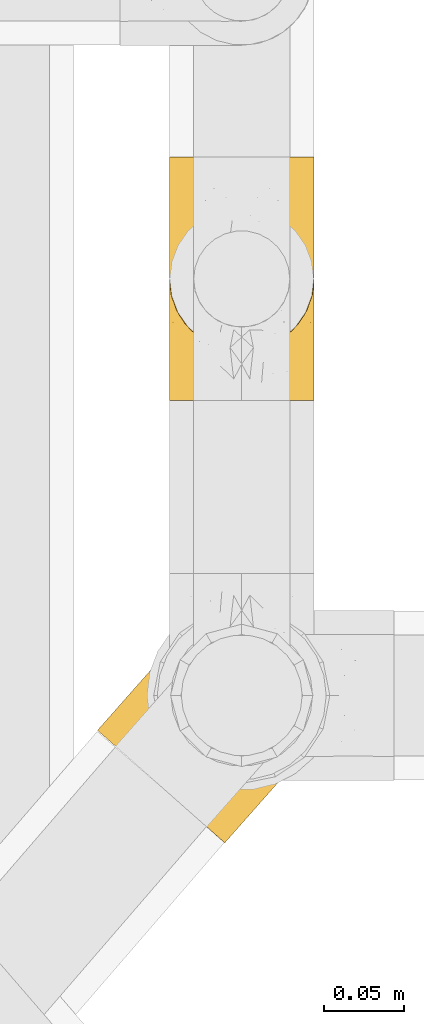
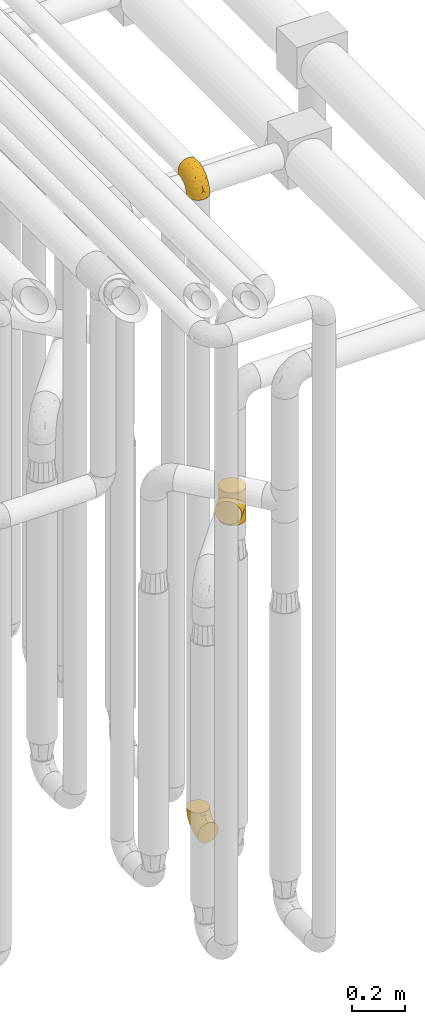
# One storey, part 207 of 827: 3 coverings.
"""IFC2X3 building model written with IfcOpenShell, lengths in millimetres."""

from ifc_helpers import new_model, entity, si_unit, converted_unit, derived_unit, direction, frame, origin, place, context, subcontext, project, spatial, faceted_brep, element, save


model = new_model("IFC2X3")

# Units and contexts
model_context = context("Model", 3, precision=0.01, world=origin(), true_north=direction((6.12303176911189e-17, 1.0)))
body_context = subcontext(model_context, "Body", "Model", "MODEL_VIEW")
ifc_project = project(units=[si_unit("LENGTHUNIT", "METRE", prefix="MILLI"), si_unit("AREAUNIT", "SQUARE_METRE"), si_unit("VOLUMEUNIT", "CUBIC_METRE"), converted_unit("PLANEANGLEUNIT", "DEGREE", entity("IfcRatioMeasure", 0.0174532925199433), si_unit("PLANEANGLEUNIT", "RADIAN"), dimensions=[0, 0, 0, 0, 0, 0, 0]), si_unit("MASSUNIT", "GRAM", prefix="KILO"), derived_unit("MASSDENSITYUNIT", [(si_unit("MASSUNIT", "GRAM", prefix="KILO"), 1), (si_unit("LENGTHUNIT", "METRE"), -3)]), derived_unit("MOMENTOFINERTIAUNIT", [(si_unit("LENGTHUNIT", "METRE"), 4)]), si_unit("TIMEUNIT", "SECOND"), si_unit("FREQUENCYUNIT", "HERTZ"), si_unit("THERMODYNAMICTEMPERATUREUNIT", "DEGREE_CELSIUS"), derived_unit("THERMALTRANSMITTANCEUNIT", [(si_unit("MASSUNIT", "GRAM", prefix="KILO"), 1), (si_unit("THERMODYNAMICTEMPERATUREUNIT", "KELVIN"), -1), (si_unit("TIMEUNIT", "SECOND"), -3)]), derived_unit("VOLUMETRICFLOWRATEUNIT", [(si_unit("LENGTHUNIT", "METRE"), 3), (si_unit("TIMEUNIT", "SECOND"), -1)]), derived_unit("MASSFLOWRATEUNIT", [(si_unit("MASSUNIT", "GRAM", prefix="KILO"), 1), (si_unit("TIMEUNIT", "SECOND"), -1)]), derived_unit("ROTATIONALFREQUENCYUNIT", [(si_unit("TIMEUNIT", "SECOND"), -1)]), si_unit("ELECTRICCURRENTUNIT", "AMPERE"), si_unit("ELECTRICVOLTAGEUNIT", "VOLT"), si_unit("POWERUNIT", "WATT"), si_unit("FORCEUNIT", "NEWTON", prefix="KILO"), si_unit("ILLUMINANCEUNIT", "LUX"), si_unit("LUMINOUSFLUXUNIT", "LUMEN"), si_unit("LUMINOUSINTENSITYUNIT", "CANDELA"), derived_unit("USERDEFINED", [(si_unit("MASSUNIT", "GRAM", prefix="KILO"), -1), (si_unit("LENGTHUNIT", "METRE"), -2), (si_unit("TIMEUNIT", "SECOND"), 3), (si_unit("LUMINOUSFLUXUNIT", "LUMEN"), 1)]), derived_unit("LINEARVELOCITYUNIT", [(si_unit("LENGTHUNIT", "METRE"), 1), (si_unit("TIMEUNIT", "SECOND"), -1)]), si_unit("PRESSUREUNIT", "PASCAL"), derived_unit("USERDEFINED", [(si_unit("LENGTHUNIT", "METRE"), -2), (si_unit("MASSUNIT", "GRAM", prefix="KILO"), 1), (si_unit("TIMEUNIT", "SECOND"), -2)]), derived_unit("LINEARFORCEUNIT", [(si_unit("MASSUNIT", "GRAM", prefix="KILO"), 1), (si_unit("LENGTHUNIT", "METRE"), 1), (si_unit("TIMEUNIT", "SECOND"), -2), (si_unit("LENGTHUNIT", "METRE"), -1)]), derived_unit("PLANARFORCEUNIT", [(si_unit("MASSUNIT", "GRAM", prefix="KILO"), 1), (si_unit("LENGTHUNIT", "METRE"), 1), (si_unit("TIMEUNIT", "SECOND"), -2), (si_unit("LENGTHUNIT", "METRE"), -2)])], contexts=[model_context])

# Site, building, storey
site_placement = place(None, origin())
site = spatial("IfcSite", under=ifc_project, at=site_placement, CompositionType="ELEMENT")
building_placement = place(site_placement, origin())
building = spatial("IfcBuilding", under=site, at=building_placement, CompositionType="ELEMENT")
storey_placement = place(building_placement, frame((0.0, 0.0, 28200.0)))
storey = spatial("IfcBuildingStorey", under=building, at=storey_placement, Name="08", CompositionType="ELEMENT", Elevation=28200.0)

# Coverings
covering_1_placement = place(storey_placement, frame((36928.29, 10662.61, 353.25)))
element("IfcCovering", 1, at=covering_1_placement, inside=storey, Name=":ADSK_", ObjectType=":ADSK_", PredefinedType="INSULATION", context=body_context, shape_type="Brep", body=[
    faceted_brep([(90.76, 87.65, 122.75), (87.42, 97.19, 122.75), (82.04, 105.75, 122.75), (74.89, 112.9, 122.75), (66.33, 118.28, 122.75), (56.79, 121.61, 122.75), (46.75, 122.75, 122.75), (36.69, 121.61, 122.75), (27.15, 118.27, 122.75), (18.59, 112.89, 122.75), (11.44, 105.74, 122.75), (6.06, 97.18, 122.75), (2.73, 87.64, 122.75), (1.6, 77.6, 122.75), (2.73, 67.54, 122.75), (6.07, 58.0, 122.75), (11.45, 49.44, 122.75), (18.6, 42.29, 122.75), (27.16, 36.91, 122.75), (36.7, 33.58, 122.75), (46.75, 32.45, 122.75), (56.8, 33.58, 122.75), (66.34, 36.92, 122.75), (74.9, 42.3, 122.75), (82.05, 49.45, 122.75), (87.43, 58.01, 122.75), (90.76, 67.55, 122.75), (91.9, 77.6, 122.75), (35.06, 1.6, 90.36), (24.17, 1.6, 85.85), (14.82, 1.6, 78.67), (7.64, 1.6, 69.32), (3.13, 1.6, 58.43), (1.6, 1.6, 46.75), (3.13, 1.6, 35.06), (7.64, 1.6, 24.17), (14.82, 1.6, 14.82), (24.17, 1.6, 7.64), (35.06, 1.6, 3.13), (46.75, 1.6, 1.6), (58.43, 1.6, 3.13), (69.32, 1.6, 7.64), (78.67, 1.6, 14.82), (85.85, 1.6, 24.17), (90.36, 1.6, 35.06), (91.9, 1.6, 46.75), (90.36, 1.6, 58.43), (85.85, 1.6, 69.32), (78.67, 1.6, 78.67), (69.32, 1.6, 85.85), (58.43, 1.6, 90.36), (46.75, 1.6, 91.9), (46.75, 99.61, 51.54), (55.2, 95.26, 47.17), (46.75, 86.21, 38.13), (46.75, 39.03, 7.52), (54.53, 30.75, 5.85), (46.75, 23.8, 5.11), (59.63, 60.8, 19.2), (62.07, 85.37, 38.98), (71.86, 73.64, 35.02), (62.65, 31.01, 8.21), (71.33, 49.14, 19.28), (72.93, 23.88, 12.19), (91.2, 82.74, 101.39), (86.31, 43.48, 34.43), (80.89, 29.47, 20.95), (79.49, 56.38, 30.74), (90.68, 72.18, 72.93), (86.84, 72.24, 56.64), (87.38, 87.6, 80.81), (76.87, 107.24, 93.43), (83.73, 101.1, 100.76), (81.03, 95.16, 74.27), (91.9, 71.81, 93.66), (91.9, 63.57, 81.33), (91.9, 55.34, 69.01), (91.03, 23.66, 40.87), (87.58, 20.55, 29.38), (56.52, 107.97, 67.05), (46.75, 116.82, 85.31), (60.4, 117.03, 93.68), (91.9, 30.68, 52.53), (91.9, 21.51, 50.71), (91.9, 12.33, 48.88), (67.87, 106.17, 72.77), (90.35, 52.37, 51.21), (69.57, 114.51, 101.18), (46.75, 119.23, 100.54), (79.91, 78.37, 48.74), (91.9, 75.46, 112.01), (91.9, 73.63, 102.83), (74.99, 101.51, 73.88), (46.75, 72.81, 24.73), (91.9, 43.01, 60.77), (88.53, 92.6, 103.08), (72.65, 91.86, 54.8), (46.75, 55.92, 16.13), (62.97, 99.01, 55.92), (46.75, 108.21, 68.42), (66.2, 32.05, 104.98), (56.6, 30.22, 108.58), (59.89, 23.37, 98.21), (90.95, 28.43, 61.56), (90.22, 16.44, 60.69), (76.64, 37.1, 100.0), (71.58, 28.88, 95.88), (79.99, 33.93, 90.81), (89.54, 50.17, 84.88), (89.97, 40.57, 73.29), (81.32, 47.62, 113.4), (74.56, 39.9, 109.8), (84.15, 47.92, 102.13), (90.37, 34.27, 67.29), (87.82, 24.65, 70.34), (90.98, 62.6, 95.15), (90.96, 66.18, 105.49), (85.14, 11.74, 71.5), (58.11, 13.89, 92.87), (46.75, 17.02, 96.03), (78.39, 15.86, 81.34), (88.22, 57.71, 107.44), (66.06, 9.11, 88.36), (68.6, 18.55, 90.43), (63.78, 34.74, 114.37), (88.42, 54.95, 98.41), (90.61, 57.35, 88.73), (83.8, 22.03, 76.89), (77.98, 24.8, 86.08), (91.22, 69.07, 112.64), (83.46, 42.31, 94.21), (46.75, 29.63, 112.22), (46.75, 28.31, 107.32), (84.66, 30.23, 79.95), (86.33, 40.13, 84.51), (46.75, 22.67, 101.67), (46.75, 12.12, 94.71), (15.1, 15.86, 81.34), (9.69, 22.03, 76.89), (15.52, 24.8, 86.08), (8.83, 30.23, 79.96), (35.39, 13.88, 92.87), (12.18, 47.61, 113.41), (1.6, 73.63, 102.83), (2.53, 66.17, 105.5), (2.27, 69.07, 112.64), (36.9, 30.22, 108.58), (27.31, 32.04, 104.98), (33.62, 23.36, 98.2), (5.07, 54.93, 98.4), (9.36, 47.91, 102.13), (5.27, 57.69, 107.44), (27.43, 9.1, 88.36), (1.6, 21.51, 50.71), (1.6, 12.33, 48.88), (10.05, 42.29, 94.22), (16.87, 37.09, 100.01), (8.35, 11.74, 71.5), (3.27, 16.44, 60.69), (1.6, 30.68, 52.53), (21.94, 28.86, 95.89), (29.72, 34.74, 114.37), (1.6, 63.57, 81.33), (1.6, 55.34, 69.01), (3.96, 50.17, 84.88), (1.6, 75.46, 112.01), (18.95, 39.89, 109.8), (2.54, 28.43, 61.56), (3.12, 34.27, 67.29), (1.6, 43.01, 60.77), (2.51, 62.59, 95.14), (3.52, 40.57, 73.29), (7.17, 40.13, 84.53), (1.6, 71.81, 93.66), (13.52, 33.92, 90.82), (2.88, 57.34, 88.73), (5.67, 24.65, 70.34), (24.89, 18.54, 90.43), (12.6, 29.47, 20.95), (7.18, 43.48, 34.43), (14.0, 56.4, 30.74), (22.16, 49.17, 19.29), (21.61, 73.69, 35.07), (3.14, 52.37, 51.21), (6.65, 72.26, 56.67), (20.82, 91.88, 54.85), (31.41, 85.36, 38.98), (5.91, 20.55, 29.38), (2.46, 23.66, 40.87), (33.87, 60.8, 19.2), (30.84, 31.02, 8.21), (38.96, 30.75, 5.85), (20.56, 23.9, 12.19), (2.81, 72.17, 72.93), (6.1, 87.59, 80.83), (2.29, 82.74, 101.39), (33.08, 117.03, 93.69), (16.61, 107.23, 93.43), (36.96, 107.97, 67.04), (9.75, 101.08, 100.76), (25.61, 106.17, 72.78), (30.5, 99.01, 55.93), (23.91, 114.5, 101.18), (12.45, 95.15, 74.27), (18.49, 101.5, 73.89), (4.96, 92.59, 103.09), (13.56, 78.38, 48.78), (38.28, 95.27, 47.19)], [[[0, 1, 2, 3, 4, 5, 6, 7, 8, 9, 10, 11, 12, 13, 14, 15, 16, 17, 18, 19, 20, 21, 22, 23, 24, 25, 26, 27]], [[28, 29, 30, 31, 32, 33, 34, 35, 36, 37, 38, 39, 40, 41, 42, 43, 44, 45, 46, 47, 48, 49, 50, 51]], [[52, 53, 54]], [[55, 56, 57]], [[58, 59, 60]], [[61, 62, 63]], [[27, 64, 0]], [[65, 66, 67]], [[41, 40, 61]], [[68, 69, 70]], [[66, 43, 42]], [[63, 42, 41]], [[71, 72, 73]], [[72, 2, 1]], [[68, 74, 75, 76]], [[45, 44, 77]], [[43, 78, 44]], [[79, 80, 81]], [[77, 82, 83, 84, 45]], [[79, 81, 85]], [[71, 2, 72]], [[65, 86, 77]], [[4, 81, 5]], [[66, 65, 78]], [[4, 3, 87]], [[81, 88, 5]], [[63, 66, 42]], [[68, 70, 64]], [[67, 60, 89]], [[71, 3, 2]], [[64, 27, 90, 91, 74]], [[92, 71, 73]], [[40, 57, 56]], [[59, 93, 54]], [[86, 76, 94, 82]], [[1, 0, 95]], [[58, 62, 61]], [[60, 96, 89]], [[85, 81, 87]], [[56, 97, 58]], [[65, 67, 69]], [[87, 81, 4]], [[67, 89, 69]], [[61, 63, 41]], [[95, 72, 1]], [[73, 72, 70]], [[69, 73, 70]], [[73, 89, 96]], [[3, 71, 87]], [[85, 87, 71]], [[58, 61, 56]], [[59, 58, 93]], [[76, 86, 68]], [[69, 89, 73]], [[68, 86, 69]], [[65, 69, 86]], [[68, 64, 74]], [[95, 64, 70]], [[98, 79, 85]], [[79, 52, 99, 80]], [[66, 62, 67]], [[62, 58, 60]], [[62, 60, 67]], [[59, 98, 96]], [[59, 96, 60]], [[96, 85, 92]], [[88, 81, 80]], [[88, 6, 5]], [[66, 63, 62]], [[64, 95, 0]], [[72, 95, 70]], [[77, 44, 78]], [[86, 82, 77]], [[40, 39, 57]], [[96, 98, 85]], [[40, 56, 61]], [[66, 78, 43]], [[77, 78, 65]], [[79, 98, 53]], [[96, 92, 73]], [[85, 71, 92]], [[97, 56, 55]], [[97, 93, 58]], [[53, 98, 59]], [[54, 53, 59]], [[79, 53, 52]], [[100, 101, 102]], [[46, 45, 84, 83]], [[103, 104, 82]], [[82, 104, 83]], [[105, 106, 107]], [[108, 109, 76]], [[110, 111, 112]], [[103, 113, 114]], [[115, 74, 116]], [[48, 47, 117]], [[118, 102, 119]], [[49, 48, 120]], [[74, 91, 116]], [[116, 121, 115]], [[49, 122, 50]], [[123, 106, 102]], [[124, 111, 22]], [[125, 126, 115]], [[23, 22, 111]], [[24, 110, 121]], [[120, 127, 128]], [[90, 26, 129]], [[27, 26, 90]], [[121, 125, 115]], [[24, 121, 25]], [[130, 105, 107]], [[129, 25, 116]], [[21, 20, 131]], [[120, 123, 122]], [[112, 105, 130]], [[50, 118, 51]], [[21, 124, 22]], [[101, 131, 132]], [[117, 120, 48]], [[24, 23, 110]], [[127, 114, 133]], [[75, 108, 76]], [[107, 134, 130]], [[133, 114, 113]], [[129, 116, 91]], [[25, 121, 116]], [[121, 112, 125]], [[75, 74, 115]], [[101, 135, 102]], [[131, 101, 21]], [[101, 100, 124]], [[128, 127, 133]], [[119, 136, 51, 118]], [[104, 47, 46]], [[83, 104, 46]], [[117, 104, 114]], [[101, 124, 21]], [[111, 124, 100]], [[102, 118, 123]], [[133, 134, 107]], [[111, 110, 23]], [[114, 104, 103]], [[94, 76, 109]], [[121, 110, 112]], [[122, 118, 50]], [[134, 109, 108]], [[133, 107, 128]], [[112, 108, 125]], [[126, 125, 108]], [[108, 75, 126]], [[75, 115, 126]], [[109, 134, 133]], [[130, 108, 112]], [[108, 130, 134]], [[105, 112, 111]], [[111, 100, 105]], [[106, 105, 100]], [[102, 106, 100]], [[128, 106, 123]], [[90, 129, 91]], [[25, 129, 26]], [[104, 117, 47]], [[117, 114, 127]], [[82, 94, 103]], [[113, 94, 109]], [[94, 113, 103]], [[133, 113, 109]], [[106, 128, 107]], [[123, 120, 128]], [[120, 122, 49]], [[118, 122, 123]], [[135, 101, 132]], [[135, 119, 102]], [[117, 127, 120]], [[30, 29, 137]], [[138, 139, 140]], [[51, 136, 119, 141]], [[142, 17, 16]], [[143, 144, 145]], [[146, 147, 148]], [[149, 150, 151]], [[152, 29, 28]], [[33, 32, 153, 154]], [[150, 155, 156]], [[157, 31, 30]], [[153, 158, 159]], [[29, 152, 137]], [[148, 141, 119]], [[156, 160, 147]], [[148, 135, 146]], [[137, 138, 157]], [[19, 161, 146]], [[162, 163, 164]], [[14, 13, 165]], [[153, 32, 158]], [[147, 161, 166]], [[18, 17, 166]], [[167, 168, 169]], [[166, 150, 156]], [[151, 150, 142]], [[151, 170, 149]], [[151, 16, 15]], [[171, 140, 172]], [[165, 143, 145]], [[173, 170, 144]], [[142, 166, 17]], [[19, 131, 20]], [[144, 170, 151]], [[18, 161, 19]], [[173, 144, 143]], [[140, 139, 174]], [[171, 164, 163]], [[164, 172, 155]], [[151, 15, 144]], [[145, 15, 14]], [[173, 162, 170]], [[149, 175, 164]], [[19, 146, 131]], [[132, 131, 146]], [[160, 148, 147]], [[159, 158, 167]], [[135, 132, 146]], [[158, 32, 31]], [[157, 158, 31]], [[167, 158, 176]], [[166, 161, 18]], [[146, 161, 147]], [[148, 177, 141]], [[171, 168, 140]], [[171, 163, 169]], [[151, 142, 16]], [[166, 142, 150]], [[152, 141, 177]], [[51, 141, 28]], [[138, 140, 176]], [[172, 140, 174]], [[175, 149, 170]], [[164, 150, 149]], [[170, 162, 175]], [[162, 164, 175]], [[155, 172, 174]], [[171, 172, 164]], [[155, 174, 156]], [[164, 155, 150]], [[160, 156, 174]], [[147, 166, 156]], [[139, 160, 174]], [[148, 160, 177]], [[15, 145, 144]], [[165, 145, 14]], [[137, 157, 30]], [[158, 157, 176]], [[168, 167, 176]], [[169, 159, 167]], [[140, 168, 176]], [[169, 168, 171]], [[137, 177, 139]], [[160, 139, 177]], [[141, 152, 28]], [[137, 152, 177]], [[148, 119, 135]], [[157, 138, 176]], [[139, 138, 137]], [[178, 179, 180]], [[181, 180, 182]], [[179, 183, 184]], [[185, 186, 182]], [[187, 188, 179]], [[188, 33, 154, 153, 159]], [[181, 189, 190]], [[35, 34, 187]], [[191, 38, 190]], [[192, 178, 181]], [[179, 184, 180]], [[192, 190, 37]], [[37, 190, 38]], [[36, 35, 178]], [[54, 93, 186]], [[35, 187, 178]], [[193, 194, 184]], [[195, 173, 143, 165, 13]], [[195, 193, 173]], [[193, 163, 162, 173]], [[13, 12, 195]], [[8, 7, 196]], [[9, 197, 10]], [[198, 80, 99, 52]], [[196, 7, 88]], [[197, 199, 10]], [[182, 189, 181]], [[200, 198, 201]], [[200, 196, 198]], [[9, 8, 202]], [[194, 199, 203]], [[192, 37, 36]], [[80, 196, 88]], [[183, 159, 169, 163]], [[188, 34, 33]], [[202, 200, 197]], [[185, 203, 204]], [[202, 8, 196]], [[10, 199, 11]], [[12, 11, 205]], [[38, 191, 57]], [[189, 97, 191]], [[203, 199, 197]], [[205, 199, 194]], [[204, 203, 197]], [[184, 203, 206]], [[200, 202, 196]], [[197, 9, 202]], [[207, 54, 186]], [[97, 55, 191]], [[194, 203, 184]], [[183, 163, 193]], [[184, 206, 180]], [[183, 193, 184]], [[205, 195, 12]], [[193, 195, 194]], [[80, 198, 196]], [[207, 186, 201]], [[182, 180, 206]], [[181, 178, 180]], [[185, 182, 206]], [[182, 186, 189]], [[203, 185, 206]], [[185, 200, 201]], [[7, 6, 88]], [[178, 192, 36]], [[190, 192, 181]], [[199, 205, 11]], [[195, 205, 194]], [[159, 183, 188]], [[179, 188, 183]], [[57, 191, 55]], [[57, 39, 38]], [[189, 191, 190]], [[188, 187, 34]], [[178, 187, 179]], [[186, 93, 189]], [[197, 200, 204]], [[185, 204, 200]], [[189, 93, 97]], [[207, 198, 52]], [[185, 201, 186]], [[198, 207, 201]], [[54, 207, 52]]]),
])
covering_2_placement = place(storey_placement, frame((36928.29, 10693.46, 3322.4)))
element("IfcCovering", 2, at=covering_2_placement, inside=storey, Name=":ADSK_", ObjectType=":ADSK_", PredefinedType="INSULATION", context=body_context, shape_type="Brep", body=[
    faceted_brep([(2.73, 122.75, 87.65), (6.07, 122.75, 97.19), (11.45, 122.75, 105.75), (18.6, 122.75, 112.9), (27.16, 122.75, 118.28), (36.7, 122.75, 121.61), (46.75, 122.75, 122.75), (56.8, 122.75, 121.61), (66.34, 122.75, 118.27), (74.9, 122.75, 112.89), (82.05, 122.75, 105.74), (87.43, 122.75, 97.18), (90.76, 122.75, 87.64), (91.9, 122.75, 77.6), (90.76, 122.75, 67.54), (87.42, 122.75, 58.0), (82.04, 122.75, 49.44), (74.89, 122.75, 42.29), (66.33, 122.75, 36.91), (56.79, 122.75, 33.58), (46.75, 122.75, 32.45), (36.69, 122.75, 33.58), (27.15, 122.75, 36.92), (18.59, 122.75, 42.3), (11.44, 122.75, 49.45), (6.06, 122.75, 58.01), (2.73, 122.75, 67.55), (1.6, 122.75, 77.6), (58.43, 90.36, 1.6), (69.32, 85.85, 1.6), (78.67, 78.67, 1.6), (85.85, 69.32, 1.6), (90.36, 58.43, 1.6), (91.9, 46.75, 1.6), (90.36, 35.06, 1.6), (85.85, 24.17, 1.6), (78.67, 14.82, 1.6), (69.32, 7.64, 1.6), (58.43, 3.13, 1.6), (46.75, 1.6, 1.6), (35.06, 3.13, 1.6), (24.17, 7.64, 1.6), (14.82, 14.82, 1.6), (7.64, 24.17, 1.6), (3.13, 35.06, 1.6), (1.6, 46.75, 1.6), (3.13, 58.43, 1.6), (7.64, 69.32, 1.6), (14.82, 78.67, 1.6), (24.17, 85.85, 1.6), (35.06, 90.36, 1.6), (46.75, 91.9, 1.6), (46.75, 51.54, 99.61), (38.29, 47.17, 95.26), (46.75, 38.13, 86.21), (46.75, 7.52, 39.03), (38.96, 5.85, 30.75), (46.75, 5.11, 23.8), (33.86, 19.2, 60.8), (31.42, 38.98, 85.37), (21.63, 35.02, 73.64), (30.84, 8.21, 31.01), (22.16, 19.28, 49.14), (20.56, 12.19, 23.88), (2.29, 101.39, 82.74), (7.18, 34.43, 43.48), (12.6, 20.95, 29.47), (14.0, 30.74, 56.38), (2.81, 72.93, 72.18), (6.65, 56.64, 72.24), (6.11, 80.81, 87.6), (16.62, 93.43, 107.24), (9.76, 100.76, 101.1), (12.46, 74.27, 95.16), (1.6, 93.66, 71.81), (1.6, 81.33, 63.57), (1.6, 69.01, 55.34), (2.46, 40.87, 23.66), (5.91, 29.38, 20.55), (36.97, 67.05, 107.97), (46.75, 85.31, 116.82), (33.09, 93.68, 117.03), (1.6, 52.53, 30.68), (1.6, 50.71, 21.51), (1.6, 48.88, 12.33), (25.62, 72.77, 106.17), (3.14, 51.21, 52.37), (23.92, 101.18, 114.51), (46.75, 100.54, 119.23), (13.58, 48.74, 78.37), (1.6, 112.01, 75.46), (1.6, 102.83, 73.63), (18.5, 73.88, 101.51), (46.75, 24.73, 72.81), (1.6, 60.77, 43.01), (4.96, 103.08, 92.6), (20.84, 54.8, 91.86), (46.75, 16.13, 55.92), (30.52, 55.92, 99.01), (46.75, 68.42, 108.21), (27.29, 104.98, 32.05), (36.89, 108.58, 30.22), (33.6, 98.21, 23.37), (2.54, 61.56, 28.43), (3.27, 60.69, 16.44), (16.85, 100.0, 37.1), (21.91, 95.88, 28.88), (13.5, 90.81, 33.93), (3.96, 84.88, 50.17), (3.52, 73.29, 40.57), (12.17, 113.4, 47.62), (18.93, 109.8, 39.9), (9.34, 102.13, 47.92), (3.12, 67.29, 34.27), (5.67, 70.34, 24.65), (2.51, 95.15, 62.6), (2.53, 105.49, 66.18), (8.35, 71.5, 11.74), (35.39, 92.87, 13.89), (46.75, 96.03, 17.02), (15.1, 81.34, 15.86), (5.27, 107.44, 57.71), (27.43, 88.36, 9.11), (24.89, 90.43, 18.55), (29.71, 114.37, 34.74), (5.07, 98.41, 54.95), (2.88, 88.73, 57.35), (9.69, 76.89, 22.03), (15.51, 86.08, 24.8), (2.27, 112.64, 69.07), (10.03, 94.21, 42.31), (46.75, 112.22, 29.63), (46.75, 107.32, 28.31), (8.83, 79.95, 30.23), (7.16, 84.51, 40.13), (46.75, 101.67, 22.67), (46.75, 94.71, 12.12), (78.39, 81.34, 15.86), (83.8, 76.89, 22.03), (77.97, 86.08, 24.8), (84.66, 79.96, 30.23), (58.1, 92.87, 13.88), (81.31, 113.41, 47.61), (91.9, 102.83, 73.63), (90.96, 105.5, 66.17), (91.22, 112.64, 69.07), (56.59, 108.58, 30.22), (66.18, 104.98, 32.04), (59.87, 98.2, 23.36), (88.42, 98.4, 54.93), (84.13, 102.13, 47.91), (88.22, 107.44, 57.69), (66.06, 88.36, 9.1), (91.9, 50.71, 21.51), (91.9, 48.88, 12.33), (83.44, 94.22, 42.29), (76.62, 100.01, 37.09), (85.14, 71.5, 11.74), (90.22, 60.69, 16.44), (91.9, 52.53, 30.68), (71.55, 95.89, 28.86), (63.77, 114.37, 34.74), (91.9, 81.33, 63.57), (91.9, 69.01, 55.34), (89.53, 84.88, 50.17), (91.9, 112.01, 75.46), (74.55, 109.8, 39.89), (90.95, 61.56, 28.43), (90.37, 67.29, 34.27), (91.9, 60.77, 43.01), (90.98, 95.14, 62.59), (89.97, 73.29, 40.57), (86.32, 84.53, 40.13), (91.9, 93.66, 71.81), (79.97, 90.82, 33.92), (90.61, 88.73, 57.34), (87.82, 70.34, 24.65), (68.6, 90.43, 18.54), (80.89, 20.95, 29.47), (86.31, 34.43, 43.48), (79.49, 30.74, 56.4), (71.33, 19.29, 49.17), (71.88, 35.07, 73.69), (90.35, 51.21, 52.37), (86.85, 56.67, 72.26), (72.67, 54.85, 91.88), (62.08, 38.98, 85.36), (87.58, 29.38, 20.55), (91.03, 40.87, 23.66), (59.62, 19.2, 60.8), (62.65, 8.21, 31.02), (54.53, 5.85, 30.75), (72.93, 12.19, 23.9), (90.68, 72.93, 72.17), (87.39, 80.83, 87.59), (91.2, 101.39, 82.74), (60.41, 93.69, 117.03), (76.88, 93.43, 107.23), (56.53, 67.04, 107.97), (83.74, 100.76, 101.08), (67.88, 72.78, 106.17), (62.99, 55.93, 99.01), (69.58, 101.18, 114.5), (81.04, 74.27, 95.15), (75.0, 73.89, 101.5), (88.53, 103.09, 92.59), (79.93, 48.78, 78.38), (55.21, 47.19, 95.27)], [[[0, 1, 2, 3, 4, 5, 6, 7, 8, 9, 10, 11, 12, 13, 14, 15, 16, 17, 18, 19, 20, 21, 22, 23, 24, 25, 26, 27]], [[28, 29, 30, 31, 32, 33, 34, 35, 36, 37, 38, 39, 40, 41, 42, 43, 44, 45, 46, 47, 48, 49, 50, 51]], [[52, 53, 54]], [[55, 56, 57]], [[58, 59, 60]], [[61, 62, 63]], [[27, 64, 0]], [[65, 66, 67]], [[41, 40, 61]], [[68, 69, 70]], [[66, 43, 42]], [[63, 42, 41]], [[71, 72, 73]], [[72, 2, 1]], [[68, 74, 75, 76]], [[45, 44, 77]], [[43, 78, 44]], [[79, 80, 81]], [[77, 82, 83, 84, 45]], [[79, 81, 85]], [[71, 2, 72]], [[65, 86, 77]], [[4, 81, 5]], [[66, 65, 78]], [[4, 3, 87]], [[81, 88, 5]], [[63, 66, 42]], [[68, 70, 64]], [[67, 60, 89]], [[71, 3, 2]], [[64, 27, 90, 91, 74]], [[92, 71, 73]], [[40, 57, 56]], [[59, 93, 54]], [[86, 76, 94, 82]], [[1, 0, 95]], [[58, 62, 61]], [[60, 96, 89]], [[85, 81, 87]], [[56, 97, 58]], [[65, 67, 69]], [[87, 81, 4]], [[67, 89, 69]], [[61, 63, 41]], [[95, 72, 1]], [[73, 72, 70]], [[69, 73, 70]], [[73, 89, 96]], [[3, 71, 87]], [[85, 87, 71]], [[58, 61, 56]], [[59, 58, 93]], [[76, 86, 68]], [[69, 89, 73]], [[68, 86, 69]], [[65, 69, 86]], [[68, 64, 74]], [[95, 64, 70]], [[98, 79, 85]], [[79, 52, 99, 80]], [[66, 62, 67]], [[62, 58, 60]], [[62, 60, 67]], [[59, 98, 96]], [[59, 96, 60]], [[96, 85, 92]], [[88, 81, 80]], [[88, 6, 5]], [[66, 63, 62]], [[64, 95, 0]], [[72, 95, 70]], [[77, 44, 78]], [[86, 82, 77]], [[40, 39, 57]], [[96, 98, 85]], [[40, 56, 61]], [[66, 78, 43]], [[77, 78, 65]], [[79, 98, 53]], [[96, 92, 73]], [[85, 71, 92]], [[97, 56, 55]], [[97, 93, 58]], [[53, 98, 59]], [[54, 53, 59]], [[79, 53, 52]], [[100, 101, 102]], [[46, 45, 84, 83]], [[103, 104, 82]], [[82, 104, 83]], [[105, 106, 107]], [[108, 109, 76]], [[110, 111, 112]], [[103, 113, 114]], [[115, 74, 116]], [[48, 47, 117]], [[118, 102, 119]], [[49, 48, 120]], [[74, 91, 116]], [[116, 121, 115]], [[49, 122, 50]], [[123, 106, 102]], [[124, 111, 22]], [[125, 126, 115]], [[23, 22, 111]], [[24, 110, 121]], [[120, 127, 128]], [[90, 26, 129]], [[27, 26, 90]], [[121, 125, 115]], [[24, 121, 25]], [[130, 105, 107]], [[129, 25, 116]], [[21, 20, 131]], [[120, 123, 122]], [[112, 105, 130]], [[50, 118, 51]], [[21, 124, 22]], [[101, 131, 132]], [[117, 120, 48]], [[24, 23, 110]], [[127, 114, 133]], [[75, 108, 76]], [[107, 134, 130]], [[133, 114, 113]], [[129, 116, 91]], [[25, 121, 116]], [[121, 112, 125]], [[75, 74, 115]], [[101, 135, 102]], [[131, 101, 21]], [[101, 100, 124]], [[128, 127, 133]], [[119, 136, 51, 118]], [[104, 47, 46]], [[83, 104, 46]], [[117, 104, 114]], [[101, 124, 21]], [[111, 124, 100]], [[102, 118, 123]], [[133, 134, 107]], [[111, 110, 23]], [[114, 104, 103]], [[94, 76, 109]], [[121, 110, 112]], [[122, 118, 50]], [[134, 109, 108]], [[133, 107, 128]], [[112, 108, 125]], [[126, 125, 108]], [[108, 75, 126]], [[75, 115, 126]], [[109, 134, 133]], [[130, 108, 112]], [[108, 130, 134]], [[105, 112, 111]], [[111, 100, 105]], [[106, 105, 100]], [[102, 106, 100]], [[128, 106, 123]], [[90, 129, 91]], [[25, 129, 26]], [[104, 117, 47]], [[117, 114, 127]], [[82, 94, 103]], [[113, 94, 109]], [[94, 113, 103]], [[133, 113, 109]], [[106, 128, 107]], [[123, 120, 128]], [[120, 122, 49]], [[118, 122, 123]], [[135, 101, 132]], [[135, 119, 102]], [[117, 127, 120]], [[30, 29, 137]], [[138, 139, 140]], [[51, 136, 119, 141]], [[142, 17, 16]], [[143, 144, 145]], [[146, 147, 148]], [[149, 150, 151]], [[152, 29, 28]], [[33, 32, 153, 154]], [[150, 155, 156]], [[157, 31, 30]], [[153, 158, 159]], [[29, 152, 137]], [[148, 141, 119]], [[156, 160, 147]], [[148, 135, 146]], [[137, 138, 157]], [[19, 161, 146]], [[162, 163, 164]], [[14, 13, 165]], [[153, 32, 158]], [[147, 161, 166]], [[18, 17, 166]], [[167, 168, 169]], [[166, 150, 156]], [[151, 150, 142]], [[151, 170, 149]], [[151, 16, 15]], [[171, 140, 172]], [[165, 143, 145]], [[173, 170, 144]], [[142, 166, 17]], [[19, 131, 20]], [[144, 170, 151]], [[18, 161, 19]], [[173, 144, 143]], [[140, 139, 174]], [[171, 164, 163]], [[164, 172, 155]], [[151, 15, 144]], [[145, 15, 14]], [[173, 162, 170]], [[149, 175, 164]], [[19, 146, 131]], [[132, 131, 146]], [[160, 148, 147]], [[159, 158, 167]], [[135, 132, 146]], [[158, 32, 31]], [[157, 158, 31]], [[167, 158, 176]], [[166, 161, 18]], [[146, 161, 147]], [[148, 177, 141]], [[171, 168, 140]], [[171, 163, 169]], [[151, 142, 16]], [[166, 142, 150]], [[152, 141, 177]], [[51, 141, 28]], [[138, 140, 176]], [[172, 140, 174]], [[175, 149, 170]], [[164, 150, 149]], [[170, 162, 175]], [[162, 164, 175]], [[155, 172, 174]], [[171, 172, 164]], [[155, 174, 156]], [[164, 155, 150]], [[160, 156, 174]], [[147, 166, 156]], [[139, 160, 174]], [[148, 160, 177]], [[15, 145, 144]], [[165, 145, 14]], [[137, 157, 30]], [[158, 157, 176]], [[168, 167, 176]], [[169, 159, 167]], [[140, 168, 176]], [[169, 168, 171]], [[137, 177, 139]], [[160, 139, 177]], [[141, 152, 28]], [[137, 152, 177]], [[148, 119, 135]], [[157, 138, 176]], [[139, 138, 137]], [[178, 179, 180]], [[181, 180, 182]], [[179, 183, 184]], [[185, 186, 182]], [[187, 188, 179]], [[188, 33, 154, 153, 159]], [[181, 189, 190]], [[35, 34, 187]], [[191, 38, 190]], [[192, 178, 181]], [[179, 184, 180]], [[192, 190, 37]], [[37, 190, 38]], [[36, 35, 178]], [[54, 93, 186]], [[35, 187, 178]], [[193, 194, 184]], [[195, 173, 143, 165, 13]], [[195, 193, 173]], [[193, 163, 162, 173]], [[13, 12, 195]], [[8, 7, 196]], [[9, 197, 10]], [[198, 80, 99, 52]], [[196, 7, 88]], [[197, 199, 10]], [[182, 189, 181]], [[200, 198, 201]], [[200, 196, 198]], [[9, 8, 202]], [[194, 199, 203]], [[192, 37, 36]], [[80, 196, 88]], [[183, 159, 169, 163]], [[188, 34, 33]], [[202, 200, 197]], [[185, 203, 204]], [[202, 8, 196]], [[10, 199, 11]], [[12, 11, 205]], [[38, 191, 57]], [[189, 97, 191]], [[203, 199, 197]], [[205, 199, 194]], [[204, 203, 197]], [[184, 203, 206]], [[200, 202, 196]], [[197, 9, 202]], [[207, 54, 186]], [[97, 55, 191]], [[194, 203, 184]], [[183, 163, 193]], [[184, 206, 180]], [[183, 193, 184]], [[205, 195, 12]], [[193, 195, 194]], [[80, 198, 196]], [[207, 186, 201]], [[182, 180, 206]], [[181, 178, 180]], [[185, 182, 206]], [[182, 186, 189]], [[203, 185, 206]], [[185, 200, 201]], [[7, 6, 88]], [[178, 192, 36]], [[190, 192, 181]], [[199, 205, 11]], [[195, 205, 194]], [[159, 183, 188]], [[179, 188, 183]], [[57, 191, 55]], [[57, 39, 38]], [[189, 191, 190]], [[188, 187, 34]], [[178, 187, 179]], [[186, 93, 189]], [[197, 200, 204]], [[185, 204, 200]], [[189, 93, 97]], [[207, 198, 52]], [[185, 201, 186]], [[198, 207, 201]], [[54, 207, 52]]]),
])
covering_3_placement = place(storey_placement, frame((36883.36, 10386.53, 1974.0)))
element("IfcCovering", 3, at=covering_3_placement, inside=storey, Name=":ADSK_", ObjectType=":ADSK_", PredefinedType="INSULATION", context=body_context, shape_type="Brep", body=[
    faceted_brep([(47.55, 123.13, 68.86), (51.92, 128.8, 0.0), (44.18, 117.32, 0.0), (39.68, 104.22, 0.0), (41.21, 110.03, 54.84), (38.64, 94.84, 41.76), (38.72, 90.4, 0.0), (39.39, 102.67, 48.13), (51.92, 128.8, 76.0), (47.55, 123.13, 83.14), (51.92, 128.8, 152.0), (43.96, 116.86, 61.78), (39.1, 86.61, 35.89), (41.37, 76.81, 0.0), (44.45, 69.5, 26.62), (44.41, 70.59, 0.0), (47.45, 64.37, 0.0), (52.0, 59.14, 0.0), (56.55, 53.92, 0.0), (56.55, 53.92, 22.95), (52.0, 59.14, 152.0), (56.55, 53.92, 129.05), (56.55, 53.92, 152.0), (40.97, 78.08, 30.74), (49.67, 61.27, 23.9), (65.65, 47.44, 24.13), (65.65, 47.44, 127.87), (68.03, 46.18, 0.0), (75.5, 43.15, 27.43), (74.58, 43.93, 0.0), (81.13, 41.68, 0.0), (94.94, 40.73, 0.0), (94.85, 40.72, 38.42), (85.38, 41.0, 32.36), (103.7, 42.01, 45.24), (108.54, 43.38, 0.0), (111.82, 44.6, 52.57), (120.98, 49.46, 0.0), (125.73, 53.0, 68.06), (131.43, 58.55, 0.0), (119.18, 48.31, 60.22), (131.43, 58.55, 76.0), (125.73, 53.0, 83.94), (131.43, 58.55, 152.0), (135.89, 122.98, 152.0), (126.8, 133.43, 152.0), (115.31, 141.17, 152.0), (102.22, 145.67, 152.0), (88.4, 146.62, 152.0), (74.81, 143.97, 152.0), (62.36, 137.89, 152.0), (44.18, 117.32, 152.0), (39.68, 104.22, 152.0), (38.72, 90.4, 152.0), (41.37, 76.81, 152.0), (44.41, 70.59, 152.0), (47.45, 64.37, 152.0), (68.03, 46.18, 152.0), (74.58, 43.93, 152.0), (81.13, 41.68, 152.0), (94.94, 40.73, 152.0), (108.54, 43.38, 152.0), (120.98, 49.46, 152.0), (139.16, 70.03, 152.0), (143.66, 83.13, 152.0), (144.62, 96.95, 152.0), (141.97, 110.54, 152.0), (62.36, 137.89, 0.0), (74.81, 143.97, 0.0), (88.4, 146.62, 0.0), (102.22, 145.67, 0.0), (115.31, 141.17, 0.0), (126.8, 133.43, 0.0), (135.89, 122.98, 0.0), (141.97, 110.54, 0.0), (144.62, 96.95, 0.0), (143.66, 83.13, 0.0), (139.16, 70.03, 0.0), (43.96, 116.86, 90.22), (41.21, 110.03, 97.16), (39.39, 102.67, 103.87), (38.64, 94.84, 110.24), (39.1, 86.61, 116.11), (40.97, 78.08, 121.26), (44.45, 69.5, 125.38), (49.67, 61.27, 128.1), (75.5, 43.15, 124.57), (85.38, 41.0, 119.64), (94.85, 40.72, 113.58), (111.82, 44.6, 99.43), (119.18, 48.31, 91.78), (103.7, 42.01, 106.76), (1.6, 71.85, 76.0), (2.95, 70.65, 62.27), (6.92, 67.14, 49.47), (13.24, 61.56, 38.49), (21.47, 54.29, 30.06), (26.27, 50.05, 27.41), (31.06, 45.81, 24.76), (36.21, 41.27, 23.85), (41.35, 36.72, 22.95), (51.64, 27.63, 24.76), (56.43, 23.39, 27.41), (61.23, 19.16, 30.06), (69.46, 11.88, 38.49), (75.78, 6.3, 49.47), (79.75, 2.79, 62.27), (81.1, 1.6, 76.0), (79.75, 2.79, 89.73), (75.78, 6.3, 102.53), (69.46, 11.88, 113.51), (61.23, 19.16, 121.94), (56.43, 23.39, 124.59), (51.64, 27.63, 127.24), (41.35, 36.72, 129.05), (36.21, 41.27, 128.15), (31.06, 45.81, 127.24), (26.27, 50.05, 124.59), (21.47, 54.29, 121.94), (13.24, 61.56, 113.51), (6.92, 67.14, 102.53), (2.95, 70.65, 89.73)], [[[0, 1, 2]], [[2, 3, 4]], [[5, 3, 6]], [[5, 7, 3]], [[0, 8, 1]], [[8, 9, 10]], [[4, 11, 2]], [[7, 4, 3]], [[0, 2, 11]], [[12, 6, 13]], [[14, 13, 15, 16]], [[17, 18, 19]], [[20, 21, 22]], [[23, 12, 13]], [[24, 14, 16]], [[24, 17, 19]], [[24, 16, 17]], [[23, 13, 14]], [[6, 12, 5]], [[25, 19, 18]], [[21, 26, 22]], [[25, 18, 27]], [[28, 27, 29, 30]], [[28, 25, 27]], [[31, 32, 33]], [[28, 30, 33]], [[33, 30, 31]], [[34, 31, 35]], [[36, 35, 37]], [[38, 37, 39]], [[36, 34, 35]], [[38, 40, 37]], [[41, 38, 39]], [[42, 41, 43]], [[36, 37, 40]], [[31, 34, 32]], [[44, 45, 46, 47, 48, 49, 50, 10, 51, 52, 53, 54, 55, 56, 20, 22, 57, 58, 59, 60, 61, 62, 43, 63, 64, 65, 66]], [[1, 67, 68, 69, 70, 71, 72, 73, 74, 75, 76, 77, 39, 37, 35, 31, 30, 29, 27, 18, 17, 16, 15, 13, 6, 3, 2]], [[70, 69, 48, 47]], [[45, 72, 71, 46]], [[46, 71, 70, 47]], [[49, 68, 67, 50]], [[1, 8, 10, 50, 67]], [[48, 69, 68, 49]], [[78, 79, 51]], [[9, 78, 51]], [[10, 9, 51]], [[52, 80, 81]], [[52, 51, 79]], [[52, 81, 53]], [[80, 52, 79]], [[82, 83, 54]], [[84, 56, 55, 54]], [[84, 85, 56]], [[21, 20, 85]], [[83, 84, 54]], [[53, 82, 54]], [[85, 20, 56]], [[82, 53, 81]], [[26, 86, 57]], [[59, 87, 60]], [[86, 59, 58, 57]], [[86, 87, 59]], [[22, 26, 57]], [[87, 88, 60]], [[89, 90, 62]], [[90, 42, 62]], [[60, 91, 61]], [[91, 60, 88]], [[89, 61, 91]], [[89, 62, 61]], [[42, 43, 62]], [[41, 39, 77, 63, 43]], [[63, 77, 76, 64]], [[76, 75, 65, 64]], [[65, 75, 74, 66]], [[66, 74, 73, 44]], [[44, 73, 72, 45]], [[92, 93, 94, 95, 96, 97, 98, 99, 100, 101, 102, 103, 104, 105, 106, 107, 108, 109, 110, 111, 112, 113, 114, 115, 116, 117, 118, 119, 120, 121]], [[24, 99, 98]], [[96, 95, 12]], [[14, 98, 97, 96]], [[19, 99, 24]], [[19, 100, 99]], [[23, 14, 96]], [[12, 23, 96]], [[24, 98, 14]], [[95, 5, 12]], [[7, 5, 94]], [[94, 5, 95]], [[4, 94, 93]], [[0, 93, 92]], [[4, 7, 94]], [[0, 11, 93]], [[8, 0, 92]], [[4, 93, 11]], [[9, 92, 121]], [[121, 120, 79]], [[81, 120, 119]], [[81, 80, 120]], [[9, 8, 92]], [[79, 78, 121]], [[80, 79, 120]], [[9, 121, 78]], [[82, 119, 118]], [[84, 118, 117, 116]], [[115, 114, 21]], [[83, 82, 118]], [[85, 84, 116]], [[85, 115, 21]], [[85, 116, 115]], [[83, 118, 84]], [[119, 82, 81]], [[26, 21, 114]], [[26, 114, 113]], [[86, 113, 112, 111]], [[86, 26, 113]], [[110, 88, 87]], [[86, 111, 87]], [[87, 111, 110]], [[91, 110, 109]], [[89, 109, 108]], [[42, 108, 107]], [[89, 91, 109]], [[42, 90, 108]], [[41, 42, 107]], [[89, 108, 90]], [[110, 91, 88]], [[38, 107, 106]], [[106, 105, 36]], [[34, 105, 104]], [[34, 36, 105]], [[38, 41, 107]], [[36, 40, 106]], [[38, 106, 40]], [[33, 104, 103]], [[28, 103, 102, 101]], [[25, 101, 100]], [[33, 32, 104]], [[25, 28, 101]], [[19, 25, 100]], [[33, 103, 28]], [[104, 32, 34]]]),
])

save(model, "model.ifc")
